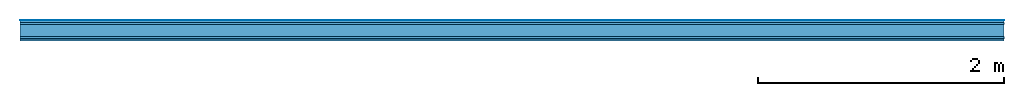
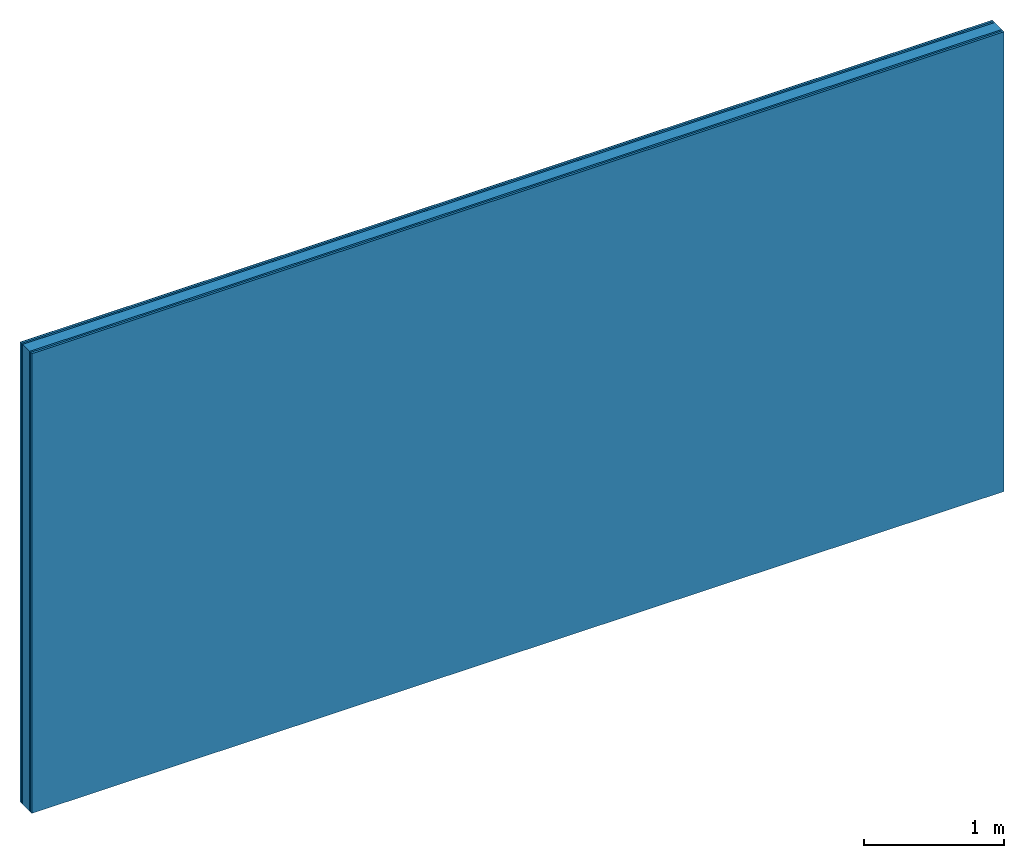
# One storey: 5 plates, 1 member, 1 element without a shape of its own.
"""IFC4 building model written with IfcOpenShell, lengths in metres."""

from ifc_helpers import new_model, si_unit, derived_unit, direction, frame, frame_2d, origin, origin_with_axes, place, context, project, spatial, rectangle, extrude, material, layer, layer_set, type_object, element, aggregate, save


model = new_model("IFC4")

# Units and contexts
plan_context = context("Plan", 3, precision=1e-05, world=origin(), true_north=direction((0.0, 1.0)))
model_context = context("Model", 3, precision=1e-05, world=origin(), true_north=direction((0.0, 1.0)))
ifc_project = project(units=[si_unit("LENGTHUNIT", "METRE"), derived_unit("SOUNDPRESSUREUNIT", [(si_unit("PRESSUREUNIT", "PASCAL", prefix="MICRO"), 0)]), si_unit("ENERGYUNIT", "JOULE", prefix="MEGA"), si_unit("MASSUNIT", "GRAM", prefix="KILO"), derived_unit("THERMALTRANSMITTANCEUNIT", [(si_unit("POWERUNIT", "WATT"), 1), (si_unit("AREAUNIT", "SQUARE_METRE"), -1), (si_unit("THERMODYNAMICTEMPERATUREUNIT", "KELVIN"), -1)]), derived_unit("AREADENSITYUNIT", [(si_unit("MASSUNIT", "GRAM", prefix="KILO"), 1), (si_unit("AREAUNIT", "SQUARE_METRE"), -1)]), derived_unit("USERDEFINED", [(si_unit("ENERGYUNIT", "JOULE", prefix="MEGA"), 1), (si_unit("AREAUNIT", "SQUARE_METRE"), -1)])], contexts=[plan_context, model_context])

# Site, building, storey
site = spatial("IfcSite", under=ifc_project)
building_placement = place(None, origin())
building = spatial("IfcBuilding", under=site, at=building_placement)
storey_placement = place(building_placement, origin())
storey = spatial("IfcBuildingStorey", under=building, at=storey_placement)

# Wall, member, plates
ifc_material_1 = material(Category="04.001")
ifc_layer_1 = layer(ifc_material_1, 0.003, Name="Surface")
ifc_material_2 = material(Category="03.007")
ifc_layer_2 = layer(ifc_material_2, 0.018, Name="2nd layer")
ifc_layer_3 = layer(ifc_material_2, 0.015, Name="1st layer")
ifc_material_3 = material(Name="of the art")
ifc_layer_4 = layer(ifc_material_3, 0.0, Name="Bond")
ifc_layer_5 = layer(None, 0.1, Name="Support")
ifc_layer_6 = layer(ifc_material_3, 0.0, Name="Bond")
ifc_layer_7 = layer(ifc_material_2, 0.015, Name="1st layer")
ifc_layer_8 = layer(ifc_material_2, 0.018, Name="2nd layer")
ifc_layer_set = layer_set([ifc_layer_1, ifc_layer_2, ifc_layer_3, ifc_layer_4, ifc_layer_5, ifc_layer_6, ifc_layer_7, ifc_layer_8])
wall_type = type_object("IfcWallType", Name="C0433", PredefinedType="NOTDEFINED", material=ifc_layer_set)
wall_placement = place(None, frame((0.0, 0.0, 0.0), z_axis=(0.0, -1.0, 0.0), x_axis=(1.0, 0.0, 0.0)))
wall = element("IfcWall", 1, at=wall_placement, inside=storey, type_object=wall_type, material=ifc_layer_set, Name="Wall #1")
ifc_material_4 = material(Name="Solid timber panel")
member_placement = place(wall_placement, origin())
member = element("IfcMember", 2, at=member_placement, material=ifc_material_4, Name="Support", context=plan_context, shape_type="SweptSolid", body=[
    extrude(rectangle(XDim=1.0, YDim=0.1, at=frame_2d((0.5, 0.05), x_axis=(1.0, 0.0))), frame((0.0, 4.0, 0.036), z_axis=(0.0, -1.0, 0.0), x_axis=(1.0, 0.0, 0.0)), (0.0, 0.0, 1.0), 4.0),
    extrude(rectangle(XDim=1.0, YDim=0.1, at=frame_2d((0.5, 0.05), x_axis=(1.0, 0.0))), frame((1.0, 4.0, 0.036), z_axis=(0.0, -1.0, 0.0), x_axis=(1.0, 0.0, 0.0)), (0.0, 0.0, 1.0), 4.0),
    extrude(rectangle(XDim=1.0, YDim=0.1, at=frame_2d((0.5, 0.05), x_axis=(1.0, 0.0))), frame((2.0, 4.0, 0.036), z_axis=(0.0, -1.0, 0.0), x_axis=(1.0, 0.0, 0.0)), (0.0, 0.0, 1.0), 4.0),
    extrude(rectangle(XDim=1.0, YDim=0.1, at=frame_2d((0.5, 0.05), x_axis=(1.0, 0.0))), frame((3.0, 4.0, 0.036), z_axis=(0.0, -1.0, 0.0), x_axis=(1.0, 0.0, 0.0)), (0.0, 0.0, 1.0), 4.0),
    extrude(rectangle(XDim=1.0, YDim=0.1, at=frame_2d((0.5, 0.05), x_axis=(1.0, 0.0))), frame((4.0, 4.0, 0.036), z_axis=(0.0, -1.0, 0.0), x_axis=(1.0, 0.0, 0.0)), (0.0, 0.0, 1.0), 4.0),
    extrude(rectangle(XDim=1.0, YDim=0.1, at=frame_2d((0.5, 0.05), x_axis=(1.0, 0.0))), frame((5.0, 4.0, 0.036), z_axis=(0.0, -1.0, 0.0), x_axis=(1.0, 0.0, 0.0)), (0.0, 0.0, 1.0), 4.0),
    extrude(rectangle(XDim=1.0, YDim=0.1, at=frame_2d((0.5, 0.05), x_axis=(1.0, 0.0))), frame((6.0, 4.0, 0.036), z_axis=(0.0, -1.0, 0.0), x_axis=(1.0, 0.0, 0.0)), (0.0, 0.0, 1.0), 4.0),
    extrude(rectangle(XDim=1.0, YDim=0.1, at=frame_2d((0.5, 0.05), x_axis=(1.0, 0.0))), frame((7.0, 4.0, 0.036), z_axis=(0.0, -1.0, 0.0), x_axis=(1.0, 0.0, 0.0)), (0.0, 0.0, 1.0), 4.0),
])
plate_1_placement = place(wall_placement, origin())
plate_1 = element("IfcPlate", 3, at=plate_1_placement, material=ifc_material_1, Name="Surface", context=plan_context, shape_type="SweptSolid", body=[
    extrude(rectangle(XDim=8.0, YDim=4.0, at=frame_2d((4.0, 2.0), x_axis=(1.0, 0.0))), origin_with_axes(), (0.0, 0.0, 1.0), 0.003),
])
plate_2_placement = place(wall_placement, origin())
plate_2 = element("IfcPlate", 4, at=plate_2_placement, material=ifc_material_2, Name="2nd layer", context=plan_context, shape_type="SweptSolid", body=[
    extrude(rectangle(XDim=8.0, YDim=4.0, at=frame_2d((4.0, 2.0), x_axis=(1.0, 0.0))), frame((0.0, 0.0, 0.003), z_axis=(0.0, 0.0, 1.0), x_axis=(1.0, 0.0, 0.0)), (0.0, 0.0, 1.0), 0.018),
])
plate_3_placement = place(wall_placement, origin())
plate_3 = element("IfcPlate", 5, at=plate_3_placement, material=ifc_material_2, Name="1st layer", context=plan_context, shape_type="SweptSolid", body=[
    extrude(rectangle(XDim=8.0, YDim=4.0, at=frame_2d((4.0, 2.0), x_axis=(1.0, 0.0))), frame((0.0, 0.0, 0.021), z_axis=(0.0, 0.0, 1.0), x_axis=(1.0, 0.0, 0.0)), (0.0, 0.0, 1.0), 0.015),
])
plate_4_placement = place(wall_placement, origin())
plate_4 = element("IfcPlate", 6, at=plate_4_placement, material=ifc_material_2, Name="1st layer", context=plan_context, shape_type="SweptSolid", body=[
    extrude(rectangle(XDim=8.0, YDim=4.0, at=frame_2d((4.0, 2.0), x_axis=(1.0, 0.0))), frame((0.0, 0.0, 0.136), z_axis=(0.0, 0.0, 1.0), x_axis=(1.0, 0.0, 0.0)), (0.0, 0.0, 1.0), 0.015),
])
plate_5_placement = place(wall_placement, origin())
plate_5 = element("IfcPlate", 7, at=plate_5_placement, material=ifc_material_2, Name="2nd layer", context=plan_context, shape_type="SweptSolid", body=[
    extrude(rectangle(XDim=8.0, YDim=4.0, at=frame_2d((4.0, 2.0), x_axis=(1.0, 0.0))), frame((0.0, 0.0, 0.151), z_axis=(0.0, 0.0, 1.0), x_axis=(1.0, 0.0, 0.0)), (0.0, 0.0, 1.0), 0.018),
])
aggregate(wall, [plate_1, plate_2, plate_3, member, plate_4, plate_5])

save(model, "model.ifc")
